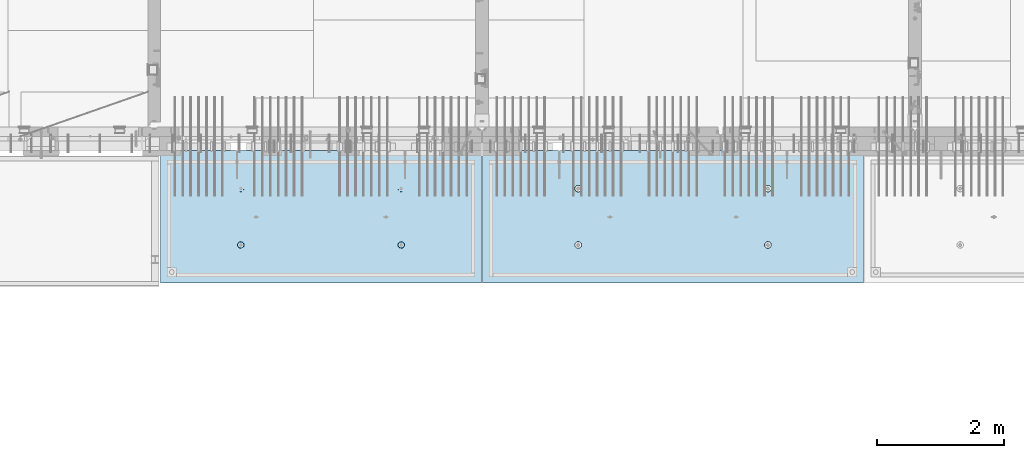
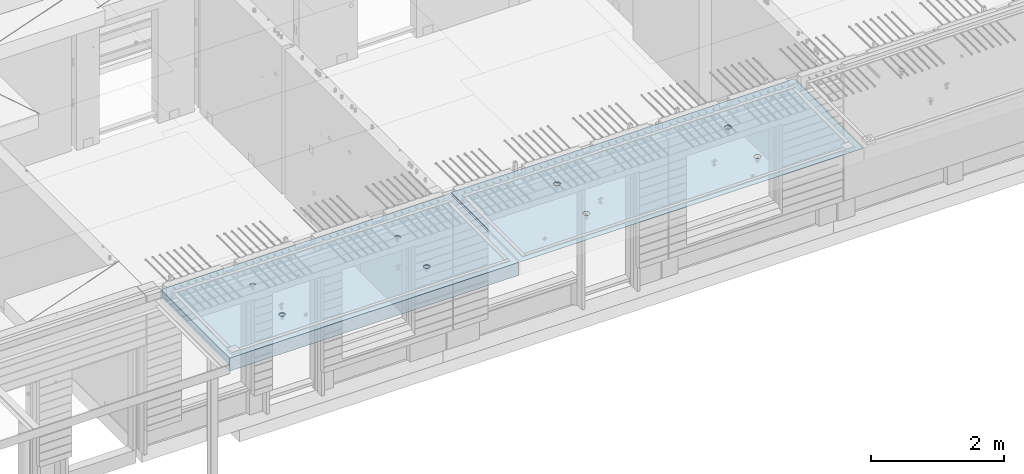
# One storey, part 180 of 325: 2 slabs, 2 elements without a shape of their own.
"""IFC2X3 building model written with IfcOpenShell, lengths in millimetres."""

from ifc_helpers import new_model, si_unit, frame, origin_with_axes, place, context, subcontext, project, spatial, faceted_brep, material, type_object, element, aggregate, save


model = new_model("IFC2X3")

# Units and contexts
model_context = context("Model", 3, precision=1e-05, world=origin_with_axes())
body_context = subcontext(model_context, "Body", "Model", "MODEL_VIEW")
ifc_project = project(units=[si_unit("LENGTHUNIT", "METRE", prefix="MILLI"), si_unit("AREAUNIT", "SQUARE_METRE"), si_unit("VOLUMEUNIT", "CUBIC_METRE"), si_unit("MASSUNIT", "GRAM", prefix="KILO"), si_unit("TIMEUNIT", "SECOND"), si_unit("PLANEANGLEUNIT", "RADIAN"), si_unit("SOLIDANGLEUNIT", "STERADIAN"), si_unit("THERMODYNAMICTEMPERATUREUNIT", "DEGREE_CELSIUS"), si_unit("LUMINOUSINTENSITYUNIT", "LUMEN")], contexts=[model_context])

# Site, building, storey
site_placement = place(None, origin_with_axes())
site = spatial("IfcSite", under=ifc_project, at=site_placement, CompositionType="ELEMENT")
building_placement = place(site_placement, origin_with_axes())
building = spatial("IfcBuilding", under=site, at=building_placement, CompositionType="ELEMENT")
storey_placement = place(building_placement, origin_with_axes())
storey = spatial("IfcBuildingStorey", under=building, at=storey_placement, Name="1", CompositionType="ELEMENT", Elevation=0.0)

# Assembly, slab
assembly_1_placement = place(storey_placement, origin_with_axes())
assembly_1 = element("IfcElementAssembly", 1, at=assembly_1_placement, inside=storey, AssemblyPlace="NOTDEFINED", PredefinedType="REINFORCEMENT_UNIT")
ifc_material = material(Name="CONCRETE/C35/45")
slab_type_1 = type_object("IfcSlabType", PredefinedType="NOTDEFINED")
slab_1_placement = place(assembly_1_placement, frame((27799.9998568133, 7629.99655735226, 84720.0), z_axis=(-1.11800000013248e-06, -0.999999999999375, 0.0), x_axis=(-0.999999999999093, 1.34699999998405e-06, 0.0)))
slab_1 = element("IfcSlab", 2, at=slab_1_placement, type_object=slab_type_1, material=ifc_material, PredefinedType="FLOOR", context=body_context, shape_type="Brep", body=[
    faceted_brep([(4430.38332613536, -4.08995228011918, 616.123557002266), (4431.90609271965, 10.0, 615.628782084005), (4439.08875686405, 10.0, 629.725594302773), (4437.8062304225, -3.95053914321761, 630.657402050439), (4450.27603094506, 10.0, 640.912894136913), (4449.35160622641, -3.83996043598745, 642.185252526786), (4464.3728266293, 10.0, 648.095590732159), (4463.88931892896, -3.76899254079035, 649.583668593681), (4479.99925133704, 10.0, 650.570591700976), (4479.99924953932, -3.74454363348195, 652.132471659324), (4495.6256817422, 10.0, 648.095626704194), (4496.1091860045, -3.76899218543258, 649.583705640341), (4509.72249396096, 10.0, 640.912962559792), (4510.64691570547, -3.83995975981816, 642.185323015524), (4520.9097937951, 10.0, 629.725688478787), (4522.19231800603, -3.95053821212787, 630.657499116635), (4528.09249039035, 10.0, 615.628892794549), (4529.6152557173, -4.08995118488383, 616.123671179757), (4530.56749135917, 10.0, 600.002468086805), (4532.18619485158, -4.24459073322942, 600.002469949934), (4528.09252636238, 10.0, 584.37603768165), (4529.64872932557, -4.39933455047139, 583.870398667863), (4520.90986221798, 10.0, 570.279225462882), (4522.24649000407, -4.53902051890327, 569.308110882728), (4509.72258813697, 10.0, 559.091925628744), (4510.70111430095, -4.6499364652409, 557.745103167879), (4495.62579245274, 10.0, 551.909229033497), (4496.142736776, -4.72117719323433, 550.318244231095), (4479.99936774499, 10.0, 549.43422806468), (4479.99936967367, -4.74573031402542, 547.758576892632), (4464.37293733984, 10.0, 551.909193061462), (4463.8559966665, -4.72117755009094, 550.318207030491), (4450.27612512107, 10.0, 559.091857205865), (4449.29760201216, -4.64993714379671, 557.745032430054), (4439.08882528693, 10.0, 570.279131286869), (4437.75219965053, -4.53902145239408, 569.308013567449), (4431.90612869169, 10.0, 584.375926971106), (4430.34992677396, -4.39933564719104, 583.87028433643), (4429.43112772287, 10.0, 600.002351678851), (4427.81242409951, -4.24459188559558, 600.002349815723), (0.0, 10.0, 0.0), (0.0, -10.0, 0.0), (0.000819232023786753, 10.0, 2085.00366210937), (5980.0, 10.0, -2.4019755073823e-09), (5980.0, -10.0, -2.4019755073823e-09), (5980.0009765625, 10.0, 2085.00366210937), (1450.3499233011, -4.39936856077111, 583.866853138679), (1451.90612877595, 10.0, 584.37249692914), (1449.43112780714, 10.0, 599.998921636884), (1447.81242044485, -4.24462478808709, 599.998919773752), (1457.75219670802, -4.53905437597132, 569.304581326389), (1459.0888253712, 10.0, 570.275701244902), (1469.29759989681, -4.64997007531929, 557.741599360567), (1470.27612520534, 10.0, 559.088427163899), (1483.85599559418, -4.7212104867067, 550.31477342891), (1484.3729374241, 10.0, 551.905763019495), (1499.99936975794, -4.74576325241651, 547.755143107666), (1499.99936782926, 10.0, 549.430798022713), (1516.14273801685, -4.72121012986463, 550.314810629518), (1515.62579253701, 10.0, 551.905798991532), (1530.70111658485, -4.64996939677803, 557.741670098397), (1529.72258822124, 10.0, 559.088495586778), (1542.24649311513, -4.53905344249506, 569.304678641675), (1540.90986230225, 10.0, 570.275795420916), (1549.64873296696, -4.39936746405147, 583.866967470121), (1548.09252644665, 10.0, 584.372607639683), (1552.18619867476, -4.24462363570638, 599.999039907971), (1550.56749144343, 10.0, 599.999038044839), (1549.61525935629, -4.08998407628678, 616.120242292795), (1548.09249047462, 10.0, 615.625462752582), (1542.19232111321, -3.95057109353365, 630.654071270945), (1540.90979387937, 10.0, 629.72225843682), (1530.64691798548, -3.83999263332225, 642.181895995745), (1529.72249404523, 10.0, 640.909532517825), (1516.10918724295, -3.76902505384351, 649.580279150618), (1515.62568182647, 10.0, 648.092196662228), (1499.99924962358, -3.7445765001321, 652.129045352205), (1499.9992514213, 10.0, 650.56716165901), (1483.88931785903, -3.76902540921583, 649.580242103954), (1484.37282671356, 10.0, 648.092160690191), (1469.35160411493, -3.83999330949155, 642.181825507), (1470.27603102933, 10.0, 640.909464094946), (1457.80622748385, -3.9505720246525, 630.653974204743), (1459.08875694832, 10.0, 629.722164260806), (1450.3833226649, -4.08998517153668, 616.120128115297), (1451.90609280392, 10.0, 615.625352042039), (1450.18528173966, 4.08930273250735, 1468.81238974452), (1450.82407776805, 10.0, 1469.01994796889), (1448.29345879993, 10.0, 1484.99752828805), (1447.63943102495, 4.24455558012414, 1484.99752753526), (1457.61190709188, 3.94915737991687, 1454.20221107617), (1458.16818327555, 10.0, 1454.60637035917), (1469.19529226424, 3.83787679090165, 1442.60118929624), (1469.60688310596, 10.0, 1443.16769686061), (1483.80158206606, 3.76640201332339, 1435.14993064656), (1484.02047762178, 10.0, 1435.82362453319), (1499.99806458492, 3.74176847410854, 1432.58187967207), (1499.99806376637, 10.0, 1433.29304234547), (1516.19454117951, 3.76640237134416, 1435.14996796955), (1515.97564408552, 10.0, 1435.82366131359), (1530.80081379559, 3.8378774716839, 1442.60126026678), (1530.38922169525, 10.0, 1443.16776682109), (1542.38417222175, 3.94915831647813, 1454.2023087116), (1541.82789519381, 10.0, 1454.6064666515), (1549.8107639085, 4.08930383282132, 1468.81250445209), (1549.17196752123, 10.0, 1469.02006116732), (1552.35657735256, 4.24455673628836, 1484.9976480647), (1551.70254970896, 10.0, 1484.99764731191), (1549.77718017658, 4.39970502781216, 1501.17188586406), (1549.17193074083, 10.0, 1500.97522763107), (1542.32982200517, 4.53957665037888, 1515.75352812725), (1541.82782523334, 10.0, 1515.38880524079), (1530.74643689407, 4.65051889081951, 1527.31927700612), (1530.38912540293, 10.0, 1526.82747873935), (1516.16088003051, 4.72171993891243, 1534.74199930817), (1515.9755308871, 10.0, 1534.17155106677), (1499.99794405534, 4.74624892331485, 1537.2991504223), (1499.99794474251, 10.0, 1536.70213325449), (1483.83501395426, 4.72171958237595, 1534.74196213963), (1484.02036442336, 10.0, 1534.17151428637), (1469.24947414505, 4.65051821242378, 1527.31920628548), (1469.60678681363, 10.0, 1526.82740877888), (1457.66611561777, 4.53957571620413, 1515.75343074172), (1458.16811331507, 10.0, 1515.38870894846), (1450.21879098044, 4.39970392896794, 1501.17177131094), (1450.82404098765, 10.0, 1500.97511443265), (4495.97553080284, 10.0, 1534.17498110874), (4496.16087879206, 4.72175280732336, 1534.74542579789), (4479.99794397108, 4.746281789965, 1537.30257672942), (4479.99794465824, 10.0, 1536.70556329646), (4510.38912531866, 10.0, 1526.83090878132), (4510.74643461406, 4.65055176430906, 1527.3227040259), (4521.82782514907, 10.0, 1515.39223528276), (4522.32981889799, 4.53960953179921, 1515.75695597294), (4529.17193065656, 10.0, 1500.97865767303), (4529.77717653759, 4.39973791921511, 1501.17531475103), (4531.70254962468, 10.0, 1485.00107735388), (4532.35657352936, 4.24458963877987, 1485.00107810666), (4529.17196743696, 10.0, 1469.02349120928), (4529.8107602671, 4.08933674640139, 1468.81593564983), (4521.82789510954, 10.0, 1454.60989669347), (4522.38416911069, 3.94919124005537, 1454.20574095265), (4510.38922161098, 10.0, 1443.17119686305), (4510.8008115117, 3.83791040322103, 1442.60469333626), (4495.97564400126, 10.0, 1435.82709135556), (4496.19453993865, 3.76643530797446, 1435.15340157113), (4479.99806368211, 10.0, 1433.29647238744), (4479.99806450065, 3.74180141248507, 1432.58531345704), (4464.02047753751, 10.0, 1435.82705457516), (4463.80158313838, 3.76643494995369, 1435.15336424814), (4449.60688302169, 10.0, 1443.17112690258), (4449.19529437959, 3.83790972242423, 1442.60462236572), (4438.16818319128, 10.0, 1454.60980040114), (4437.61191003439, 3.94919030349411, 1454.20564331723), (4430.82407768378, 10.0, 1469.02337801086), (4430.18528521251, 4.08933564607287, 1468.81582094227), (4437.66611855642, 4.53960859763902, 1515.75685858742), (4449.24947625653, 4.65055108592787, 1527.32263330526), (4463.83501502419, 4.72175245078688, 1534.74538862936), (4427.63943467959, 4.24458848261565, 1485.00095757723), (4430.2187944509, 4.39973682038544, 1501.17520019791), (4464.02036433909, 10.0, 1534.17494432834), (4449.60678672936, 10.0, 1526.83083882084), (4438.1681132308, 10.0, 1515.39213899043), (4430.82404090338, 10.0, 1500.97854447461), (4428.29345871566, 10.0, 1485.00095833002)], [[[0, 1, 2, 3]], [[3, 2, 4, 5]], [[5, 4, 6, 7]], [[7, 6, 8, 9]], [[10, 11, 9, 8]], [[12, 13, 11, 10]], [[14, 15, 13, 12]], [[16, 17, 15, 14]], [[18, 19, 17, 16]], [[20, 21, 19, 18]], [[22, 23, 21, 20]], [[24, 25, 23, 22]], [[26, 27, 25, 24]], [[27, 26, 28, 29]], [[29, 28, 30, 31]], [[31, 30, 32, 33]], [[33, 32, 34, 35]], [[35, 34, 36, 37]], [[37, 36, 38, 39]], [[39, 38, 1, 0]], [[40, 41, 42]], [[40, 43, 44, 41]], [[43, 45, 44]], [[46, 47, 48, 49]], [[50, 51, 47, 46]], [[52, 53, 51, 50]], [[54, 55, 53, 52]], [[56, 57, 55, 54]], [[58, 59, 57, 56]], [[59, 58, 60, 61]], [[61, 60, 62, 63]], [[63, 62, 64, 65]], [[65, 64, 66, 67]], [[67, 66, 68, 69]], [[69, 68, 70, 71]], [[71, 70, 72, 73]], [[73, 72, 74, 75]], [[75, 74, 76, 77]], [[78, 79, 77, 76]], [[80, 81, 79, 78]], [[82, 83, 81, 80]], [[84, 85, 83, 82]], [[49, 48, 85, 84]], [[86, 87, 88, 89]], [[90, 91, 87, 86]], [[92, 93, 91, 90]], [[94, 95, 93, 92]], [[96, 97, 95, 94]], [[98, 99, 97, 96]], [[100, 101, 99, 98]], [[101, 100, 102, 103]], [[103, 102, 104, 105]], [[105, 104, 106, 107]], [[107, 106, 108, 109]], [[109, 108, 110, 111]], [[111, 110, 112, 113]], [[113, 112, 114, 115]], [[115, 114, 116, 117]], [[117, 116, 118, 119]], [[120, 121, 119, 118]], [[122, 123, 121, 120]], [[124, 125, 123, 122]], [[89, 88, 125, 124]], [[126, 127, 128, 129]], [[130, 131, 127, 126]], [[132, 133, 131, 130]], [[134, 135, 133, 132]], [[136, 137, 135, 134]], [[138, 139, 137, 136]], [[140, 141, 139, 138]], [[142, 143, 141, 140]], [[143, 142, 144, 145]], [[145, 144, 146, 147]], [[147, 146, 148, 149]], [[149, 148, 150, 151]], [[151, 150, 152, 153]], [[153, 152, 154, 155]], [[41, 44, 45, 42], [3, 5, 7, 9, 11, 13, 15, 17, 19, 21, 23, 25, 27, 29, 31, 33, 35, 37, 39, 0], [156, 157, 158, 128, 127, 131, 133, 135, 137, 139, 141, 143, 145, 147, 149, 151, 153, 155, 159, 160], [122, 120, 118, 116, 114, 112, 110, 108, 106, 104, 102, 100, 98, 96, 94, 92, 90, 86, 89, 124], [82, 80, 78, 76, 74, 72, 70, 68, 66, 64, 62, 60, 58, 56, 54, 52, 50, 46, 49, 84]], [[129, 128, 158, 161]], [[157, 162, 161, 158]], [[156, 163, 162, 157]], [[160, 164, 163, 156]], [[159, 165, 164, 160]], [[155, 154, 165, 159]], [[43, 40, 42, 45], [34, 32, 30, 28, 26, 24, 22, 20, 18, 16, 14, 12, 10, 8, 6, 4, 2, 1, 38, 36], [152, 150, 148, 146, 144, 142, 140, 138, 136, 134, 132, 130, 126, 129, 161, 162, 163, 164, 165, 154], [91, 93, 95, 97, 99, 101, 103, 105, 107, 109, 111, 113, 115, 117, 119, 121, 123, 125, 88, 87], [51, 53, 55, 57, 59, 61, 63, 65, 67, 69, 71, 73, 75, 77, 79, 81, 83, 85, 48, 47]]]),
])
aggregate(assembly_1, [slab_1])

assembly_2_placement = place(storey_placement, origin_with_axes())
assembly_2 = element("IfcElementAssembly", 3, at=assembly_2_placement, inside=storey, AssemblyPlace="NOTDEFINED", PredefinedType="REINFORCEMENT_UNIT")
slab_type_2 = type_object("IfcSlabType", PredefinedType="NOTDEFINED")
slab_2_placement = place(assembly_2_placement, frame((21799.9998568133, 7629.99655735226, 84590.0), z_axis=(-1.11800000013248e-06, -0.999999999999375, 0.0), x_axis=(-0.999999999999093, 1.34699999998405e-06, 0.0)))
slab_2 = element("IfcSlab", 4, at=slab_2_placement, type_object=slab_type_2, material=ifc_material, PredefinedType="FLOOR", context=body_context, shape_type="Brep", body=[
    faceted_brep([(1275.44980856604, -115.0, 552.444777751491), (1289.3882117606, -115.0, 559.546772887367), (1300.44978375459, -115.0, 570.608375101608), (1307.55174081072, -115.0, 584.54679769877), (1309.9988938901, -115.0, 599.997650760343), (1307.551698599, -115.0, 615.448497136235), (1300.44970346313, -115.0, 629.3869003308), (1289.38810124889, -115.0, 640.448472324786), (1275.44967865172, -115.0, 647.550429380917), (1259.99882559015, -115.0, 649.997582460297), (1244.54797921425, -115.0, 647.550387169195), (1230.60957601969, -115.0, 640.44839203332), (1219.54800402571, -115.0, 629.386789819078), (1212.44604696957, -115.0, 615.448367221916), (1209.9988938902, -115.0, 599.997514160343), (1212.4460891813, -115.0, 584.546667784451), (1219.54808431717, -115.0, 570.608264589886), (1230.60968653141, -115.0, 559.546692595902), (1244.54810912857, -115.0, 552.444735539769), (1259.99896219015, -115.0, 549.99758246039), (1219.08841602657, -120.0, 570.274295068632), (1211.90571640051, -120.0, 584.371089208588), (1230.27571826597, -120.0, 559.087023392896), (1244.37253202901, -120.0, 551.904362279308), (1259.99896296629, -120.0, 549.429400642209), (1275.6253871419, -120.0, 551.904404970708), (1289.72218128186, -120.0, 559.087104596764), (1300.9094529576, -120.0, 570.274406836168), (1308.09211407118, -120.0, 584.371220599207), (1310.56707570828, -120.0, 599.99765153648), (1308.09207137979, -120.0, 615.624075712098), (1300.90937175373, -120.0, 629.720869852056), (1289.72206951433, -120.0, 640.90814152779), (1275.62525575129, -120.0, 648.090802641378), (1259.99882481401, -120.0, 650.565764278478), (1244.37240063839, -120.0, 648.090759949978), (1230.27560649844, -120.0, 640.908060323922), (1219.0883348227, -120.0, 629.72075808452), (1211.90567370912, -120.0, 615.623944321479), (1209.43071207202, -120.0, 599.997513384206), (0.000328360383718973, -120.0, 2085.00366210938), (5040.00048828125, -120.0, 2085.00366210938), (5040.00048828125, 120.0, 2085.00366210938), (0.000328360383718973, 120.0, 2085.00366210938), (5040.0, -120.0, -2.18278728425503e-09), (5040.0, 120.0, -2.18278728425503e-09), (-7.27595761418343e-12, -120.0, -9.09494701772928e-13), (-7.27595761418343e-12, 120.0, -9.09494701772928e-13), (1275.44859965604, -105.0, 1437.44477775066), (1289.38700285061, -105.0, 1444.54677288654), (1300.44857484459, -105.0, 1455.60837510078), (1307.55053190072, -105.0, 1469.54679769794), (1309.9976849801, -105.0, 1484.99765075952), (1307.550489689, -105.0, 1500.44849713541), (1300.44849455313, -105.0, 1514.38690032997), (1289.38689233888, -105.0, 1525.44847232396), (1275.44846974172, -105.0, 1532.55042938009), (1259.99761668015, -105.0, 1534.99758245947), (1244.54677030425, -105.0, 1532.55038716837), (1230.60836710969, -105.0, 1525.44839203249), (1219.5467951157, -105.0, 1514.38678981825), (1212.44483805958, -105.0, 1500.44836722109), (1209.99768498019, -105.0, 1484.99751415952), (1212.44488027129, -105.0, 1469.54666778362), (1219.54687540717, -105.0, 1455.60826458906), (1230.60847762142, -105.0, 1444.54669259508), (1244.54690021857, -105.0, 1437.44473553894), (1259.99775328015, -105.0, 1434.99758245956), (1210.82376192895, -120.0, 1469.01993205604), (1208.29313952565, -120.0, 1484.99751183111), (1218.16787053537, -120.0, 1454.60635602529), (1229.60657282509, -120.0, 1443.16768498606), (1244.02016891989, -120.0, 1435.82361575756), (1259.99775560856, -120.0, 1433.29303700502), (1275.97533538363, -120.0, 1435.82365940832), (1290.38891141437, -120.0, 1443.16776801474), (1301.82758245361, -120.0, 1454.60647030446), (1309.17165168211, -120.0, 1469.02006639925), (1311.70223043464, -120.0, 1484.99765308793), (1309.17160803135, -120.0, 1500.975232863), (1301.82749942493, -120.0, 1515.38880889374), (1290.3887971352, -120.0, 1526.82747993297), (1275.97520104041, -120.0, 1534.17154916147), (1259.99761435174, -120.0, 1536.70212791401), (1244.02003457667, -120.0, 1534.17150551072), (1229.60645854592, -120.0, 1526.8273969043), (1218.16778750669, -120.0, 1515.38869461457), (1210.82371827819, -120.0, 1500.97509851978), (3795.4485995714, -105.0, 1437.44822013263), (3809.38700276596, -105.0, 1444.55021526851), (3820.44857475995, -105.0, 1455.61181748275), (3827.55053181608, -105.0, 1469.55024007991), (3829.99768489545, -105.0, 1485.00109314148), (3827.55048960436, -105.0, 1500.45193951738), (3820.44849446848, -105.0, 1514.39034271194), (3809.38689225424, -105.0, 1525.45191470593), (3795.44846965708, -105.0, 1532.55387176206), (3779.9976165955, -105.0, 1535.00102484144), (3764.54677021961, -105.0, 1532.55382955034), (3750.60836702505, -105.0, 1525.45183441446), (3739.54679503106, -105.0, 1514.39023220022), (3732.44483797493, -105.0, 1500.45180960306), (3729.99768489555, -105.0, 1485.00095654148), (3732.44488018665, -105.0, 1469.55011016559), (3739.54687532252, -105.0, 1455.61170697103), (3750.60847753677, -105.0, 1444.55013497704), (3764.54690013393, -105.0, 1437.44817792091), (3779.9977531955, -105.0, 1435.00102484153), (3730.82376184431, -120.0, 1469.023374438), (3728.293139441, -120.0, 1485.00095421308), (3738.16787045072, -120.0, 1454.60979840726), (3749.60657274045, -120.0, 1443.17112736803), (3764.02016883524, -120.0, 1435.82705813953), (3779.99775552391, -120.0, 1433.29647938699), (3795.97533529898, -120.0, 1435.82710179029), (3810.38891132972, -120.0, 1443.1712103967), (3821.82758236896, -120.0, 1454.60991268643), (3829.17165159746, -120.0, 1469.02350878122), (3831.70223035, -120.0, 1485.00109546989), (3829.1716079467, -120.0, 1500.97867524497), (3821.82749934028, -120.0, 1515.39225127571), (3810.38879705056, -120.0, 1526.83092231494), (3795.97520095576, -120.0, 1534.17499154344), (3779.99761426709, -120.0, 1536.70557029598), (3764.02003449202, -120.0, 1534.17494789268), (3749.60645846128, -120.0, 1526.83083928627), (3738.16778742204, -120.0, 1515.39213699654), (3730.82371819355, -120.0, 1500.97854090175), (3795.4498084814, -115.0, 552.448220133458), (3809.38821167596, -115.0, 559.550215269334), (3820.44978366995, -115.0, 570.611817483575), (3827.55174072608, -115.0, 584.550240080738), (3829.99889380546, -115.0, 600.00109314231), (3827.55169851435, -115.0, 615.451939518203), (3820.44970337848, -115.0, 629.390342712767), (3809.38810116424, -115.0, 640.451914706753), (3795.44967856708, -115.0, 647.553871762884), (3779.9988255055, -115.0, 650.001024842264), (3764.54797912961, -115.0, 647.553829551163), (3750.60957593505, -115.0, 640.451834415288), (3739.54800394106, -115.0, 629.390232201046), (3732.44604688493, -115.0, 615.451809603883), (3729.99889380555, -115.0, 600.000956542311), (3732.44608909665, -115.0, 584.550110166418), (3739.54808423252, -115.0, 570.611706971854), (3750.60968644677, -115.0, 559.550134977869), (3764.54810904393, -115.0, 552.448177921737), (3779.9989621055, -115.0, 550.001024842357), (3731.90571631587, -120.0, 584.374531590555), (3729.43071198737, -120.0, 600.000955766174), (3739.08841594193, -120.0, 570.277737450599), (3750.27571818133, -120.0, 559.090465774863), (3764.37253194437, -120.0, 551.907804661275), (3779.99896288164, -120.0, 549.432843024176), (3795.62538705726, -120.0, 551.907847352675), (3809.72218119721, -120.0, 559.090546978732), (3820.90945287295, -120.0, 570.277849218135), (3828.09211398654, -120.0, 584.374662981175), (3830.56707562364, -120.0, 600.001093918447), (3828.09207129514, -120.0, 615.627518094066), (3820.90937166908, -120.0, 629.724312234023), (3809.72206942968, -120.0, 640.911583909758), (3795.62525566664, -120.0, 648.094245023345), (3779.99882472937, -120.0, 650.569206660445), (3764.37240055375, -120.0, 648.094202331945), (3750.27560641379, -120.0, 640.911502705889), (3739.08833473806, -120.0, 629.724200466487), (3731.90567362447, -120.0, 615.627386703446)], [[[0, 1, 2, 3, 4, 5, 6, 7, 8, 9, 10, 11, 12, 13, 14, 15, 16, 17, 18, 19]], [[20, 16, 15, 21]], [[22, 17, 16, 20]], [[23, 18, 17, 22]], [[24, 19, 18, 23]], [[25, 0, 19, 24]], [[26, 1, 0, 25]], [[27, 2, 1, 26]], [[28, 3, 2, 27]], [[29, 4, 3, 28]], [[30, 5, 4, 29]], [[31, 6, 5, 30]], [[32, 7, 6, 31]], [[33, 8, 7, 32]], [[34, 9, 8, 33]], [[35, 10, 9, 34]], [[36, 11, 10, 35]], [[37, 12, 11, 36]], [[38, 13, 12, 37]], [[39, 14, 13, 38]], [[21, 15, 14, 39]], [[40, 41, 42, 43]], [[41, 44, 45, 42]], [[44, 46, 47, 45]], [[42, 45, 47, 43]], [[46, 40, 43, 47]], [[48, 49, 50, 51, 52, 53, 54, 55, 56, 57, 58, 59, 60, 61, 62, 63, 64, 65, 66, 67]], [[68, 63, 62, 69]], [[70, 64, 63, 68]], [[71, 65, 64, 70]], [[72, 66, 65, 71]], [[73, 67, 66, 72]], [[74, 48, 67, 73]], [[75, 49, 48, 74]], [[76, 50, 49, 75]], [[77, 51, 50, 76]], [[78, 52, 51, 77]], [[79, 53, 52, 78]], [[80, 54, 53, 79]], [[81, 55, 54, 80]], [[82, 56, 55, 81]], [[83, 57, 56, 82]], [[84, 58, 57, 83]], [[85, 59, 58, 84]], [[86, 60, 59, 85]], [[87, 61, 60, 86]], [[69, 62, 61, 87]], [[88, 89, 90, 91, 92, 93, 94, 95, 96, 97, 98, 99, 100, 101, 102, 103, 104, 105, 106, 107]], [[108, 103, 102, 109]], [[110, 104, 103, 108]], [[111, 105, 104, 110]], [[112, 106, 105, 111]], [[113, 107, 106, 112]], [[114, 88, 107, 113]], [[115, 89, 88, 114]], [[116, 90, 89, 115]], [[117, 91, 90, 116]], [[118, 92, 91, 117]], [[119, 93, 92, 118]], [[120, 94, 93, 119]], [[121, 95, 94, 120]], [[122, 96, 95, 121]], [[123, 97, 96, 122]], [[124, 98, 97, 123]], [[125, 99, 98, 124]], [[126, 100, 99, 125]], [[127, 101, 100, 126]], [[109, 102, 101, 127]], [[128, 129, 130, 131, 132, 133, 134, 135, 136, 137, 138, 139, 140, 141, 142, 143, 144, 145, 146, 147]], [[148, 143, 142, 149]], [[150, 144, 143, 148]], [[151, 145, 144, 150]], [[152, 146, 145, 151]], [[153, 147, 146, 152]], [[154, 128, 147, 153]], [[155, 129, 128, 154]], [[156, 130, 129, 155]], [[157, 131, 130, 156]], [[158, 132, 131, 157]], [[159, 133, 132, 158]], [[160, 134, 133, 159]], [[161, 135, 134, 160]], [[162, 136, 135, 161]], [[163, 137, 136, 162]], [[164, 138, 137, 163]], [[165, 139, 138, 164]], [[166, 140, 139, 165]], [[167, 141, 140, 166]], [[149, 142, 141, 167]], [[44, 41, 40, 46], [37, 36, 35, 34, 33, 32, 31, 30, 29, 28, 27, 26, 25, 24, 23, 22, 20, 21, 39, 38], [166, 165, 164, 163, 162, 161, 160, 159, 158, 157, 156, 155, 154, 153, 152, 151, 150, 148, 149, 167], [126, 125, 124, 123, 122, 121, 120, 119, 118, 117, 116, 115, 114, 113, 112, 111, 110, 108, 109, 127], [86, 85, 84, 83, 82, 81, 80, 79, 78, 77, 76, 75, 74, 73, 72, 71, 70, 68, 69, 87]]]),
])
aggregate(assembly_2, [slab_2])

save(model, "model.ifc")
